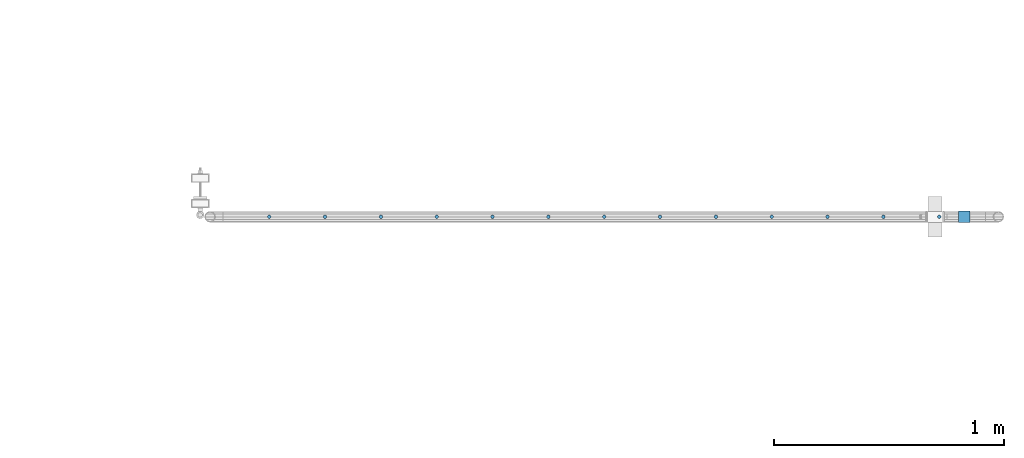
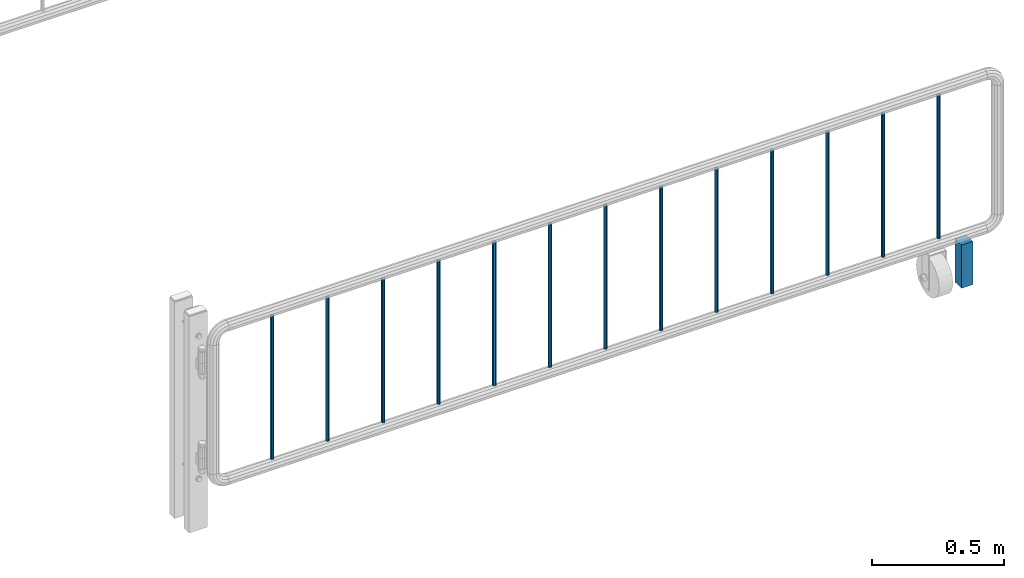
# One storey, part 101 of 247: 14 columns.
"""IFC2X3 building model written with IfcOpenShell, lengths in millimetres."""

from ifc_helpers import new_model, si_unit, frame, origin_with_axes, place, context, subcontext, project, spatial, faceted_brep, material, type_object, element, save


model = new_model("IFC2X3")

# Units and contexts
model_context = context("Model", 3, precision=1e-05, world=origin_with_axes())
body_context = subcontext(model_context, "Body", "Model", "MODEL_VIEW")
ifc_project = project(units=[si_unit("LENGTHUNIT", "METRE", prefix="MILLI"), si_unit("AREAUNIT", "SQUARE_METRE"), si_unit("VOLUMEUNIT", "CUBIC_METRE"), si_unit("MASSUNIT", "GRAM", prefix="KILO"), si_unit("TIMEUNIT", "SECOND"), si_unit("PLANEANGLEUNIT", "RADIAN"), si_unit("SOLIDANGLEUNIT", "STERADIAN"), si_unit("THERMODYNAMICTEMPERATUREUNIT", "DEGREE_CELSIUS"), si_unit("LUMINOUSINTENSITYUNIT", "LUMEN")], contexts=[model_context])

# Site, building, storey
site_placement = place(None, origin_with_axes())
site = spatial("IfcSite", under=ifc_project, at=site_placement, CompositionType="ELEMENT")
building_placement = place(site_placement, origin_with_axes())
building = spatial("IfcBuilding", under=site, at=building_placement, Name="Standard", CompositionType="ELEMENT")
storey_placement = place(building_placement, origin_with_axes())
storey = spatial("IfcBuildingStorey", under=building, at=storey_placement, Name="Undefined", CompositionType="ELEMENT", Elevation=0.0)

# Columns
ifc_material_1 = material(Name="STEEL/S355")
column_type_1 = type_object("IfcColumnType", PredefinedType="NOTDEFINED")
column_placement = place(storey_placement, frame((30182.0962679207, 5941.85337247848, 0.500000000007276), z_axis=(-1.0, 0.0, 0.0), x_axis=(0.0, 0.0, 1.0)))
element("IfcColumn", 1, at=column_placement, inside=storey, type_object=column_type_1, material=ifc_material_1, context=body_context, shape_type="Brep", body=[
    faceted_brep([(0.0, 25.0, -25.0), (0.0, 25.0, 25.0), (200.0, 25.0, 25.0), (200.0, 25.0, -25.0), (0.0, -25.0, 25.0), (200.0, -25.0, 25.0), (0.0, -25.0, -25.0), (200.0, -25.0, -25.0)], [[[0, 1, 2, 3]], [[1, 4, 5, 2]], [[4, 6, 7, 5]], [[6, 0, 3, 7]], [[5, 7, 3, 2]], [[6, 4, 1, 0]]]),
])
ifc_material_2 = material(Name="STEEL/S355J2")
column_type_2 = type_object("IfcColumnType", Name="D16", PredefinedType="NOTDEFINED")
for number, where, z_axis, x_axis in (
    (2, (27156.0962679207, 5941.85337247848, 248.800000000007), (-1.0, 0.0, 0.0), (0.0, 0.0, 1.0)),
    (3, (27399.0962679207, 5941.85337247848, 248.800000000007), (-1.0, 0.0, 0.0), (0.0, 0.0, 1.0)),
    (4, (27642.0962679207, 5941.85337247848, 248.800000000007), (-1.0, 0.0, 0.0), (0.0, 0.0, 1.0)),
    (5, (27885.0962679207, 5941.85337247848, 248.800000000007), (-1.0, 0.0, 0.0), (0.0, 0.0, 1.0)),
    (6, (28128.0962679207, 5941.85337247848, 248.800000000007), (-1.0, 0.0, 0.0), (0.0, 0.0, 1.0)),
    (7, (28371.0962679207, 5941.85337247848, 248.800000000007), (-1.0, 0.0, 0.0), (0.0, 0.0, 1.0)),
    (8, (28614.0962679207, 5941.85337247848, 248.800000000007), (-1.0, 0.0, 0.0), (0.0, 0.0, 1.0)),
    (9, (28857.0962679207, 5941.85337247848, 248.800000000007), (-1.0, 0.0, 0.0), (0.0, 0.0, 1.0)),
    (10, (29100.0962679207, 5941.85337247848, 248.800000000007), (-1.0, 0.0, 0.0), (0.0, 0.0, 1.0)),
    (11, (29343.0962679207, 5941.85337247848, 248.800000000007), (-1.0, 0.0, 0.0), (0.0, 0.0, 1.0)),
    (12, (29586.0962679207, 5941.85337247848, 248.800000000007), (-1.0, 0.0, 0.0), (0.0, 0.0, 1.0)),
    (13, (29829.0962679207, 5941.85337247848, 248.800000000007), (-1.0, 0.0, 0.0), (0.0, 0.0, 1.0)),
    (14, (30072.0962679207, 5941.85337247848, 248.800000000007), (-1.0, 0.0, 0.0), (0.0, 0.0, 1.0)),
):
    element("IfcColumn", number, at=place(storey_placement, frame(where, z_axis=z_axis, x_axis=x_axis)), inside=storey, type_object=column_type_2, material=ifc_material_2, ObjectType="D16", context=body_context, shape_type="Brep", body=[
        faceted_brep([(0.0, -8.0, 0.0), (0.0, -5.65685424949243, -5.65685424949334), (663.0, -5.65685424949243, -5.65685424949334), (663.0, -8.0, 0.0), (2.47832457164377e-12, -4.54747350886464e-13, -8.0), (663.0, 0.0, -8.0), (0.0, 5.65685424949243, -5.65685424949334), (663.0, 5.65685424949243, -5.65685424949334), (0.0, 8.0, 0.0), (663.0, 8.0, 0.0), (0.0, 5.65685424949243, 5.65685424949334), (663.0, 5.65685424949243, 5.65685424949334), (-8.29068785280258e-13, -4.54747350886464e-13, 8.0), (663.0, 0.0, 8.0), (0.0, -5.65685424949243, 5.65685424949334), (663.0, -5.65685424949243, 5.65685424949334)], [[[0, 1, 2, 3]], [[1, 4, 5, 2]], [[4, 6, 7, 5]], [[6, 8, 9, 7]], [[8, 10, 11, 9]], [[10, 12, 13, 11]], [[12, 14, 15, 13]], [[14, 0, 3, 15]], [[5, 7, 9, 11, 13, 15, 3, 2]], [[14, 12, 10, 8, 6, 4, 1, 0]]]),
    ])

save(model, "model.ifc")
